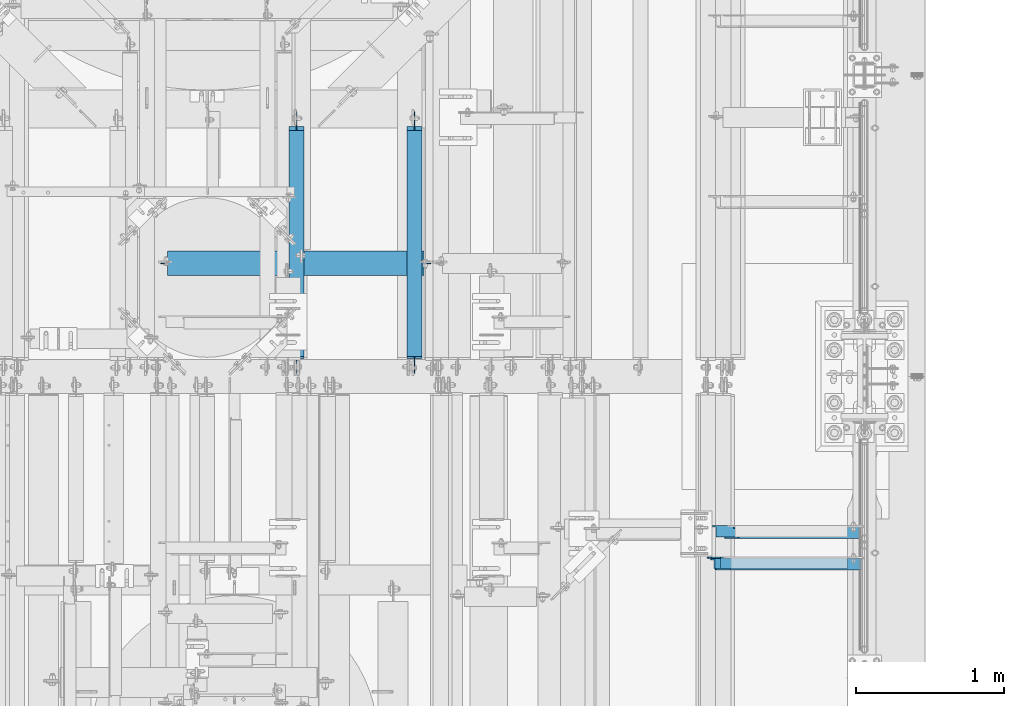
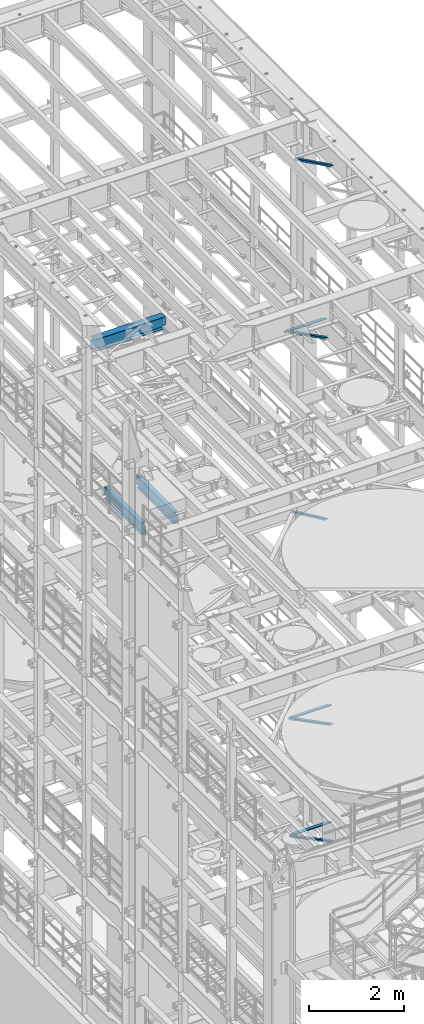
# One storey, part 1046 of 1876: 6 beams, 5 members, 11 elements without a shape of their own.
"""IFC2X3 building model written with IfcOpenShell, lengths in millimetres."""

from ifc_helpers import new_model, si_unit, frame, origin_with_axes, place, context, subcontext, project, spatial, faceted_brep, material, type_object, element, aggregate, save


model = new_model("IFC2X3")

# Units and contexts
model_context = context("Model", 3, precision=1e-05, world=origin_with_axes())
body_context = subcontext(model_context, "Body", "Model", "MODEL_VIEW")
ifc_project = project(units=[si_unit("LENGTHUNIT", "METRE", prefix="MILLI"), si_unit("AREAUNIT", "SQUARE_METRE"), si_unit("VOLUMEUNIT", "CUBIC_METRE"), si_unit("MASSUNIT", "GRAM", prefix="KILO"), si_unit("TIMEUNIT", "SECOND"), si_unit("PLANEANGLEUNIT", "RADIAN"), si_unit("SOLIDANGLEUNIT", "STERADIAN"), si_unit("THERMODYNAMICTEMPERATUREUNIT", "DEGREE_CELSIUS"), si_unit("LUMINOUSINTENSITYUNIT", "LUMEN")], contexts=[model_context])

# Site, building, storey
site_placement = place(None, origin_with_axes())
site = spatial("IfcSite", under=ifc_project, at=site_placement, CompositionType="ELEMENT")
building_placement = place(site_placement, origin_with_axes())
building = spatial("IfcBuilding", under=site, at=building_placement, Name="Undefined", CompositionType="ELEMENT")
storey_placement = place(building_placement, origin_with_axes())
storey = spatial("IfcBuildingStorey", under=building, at=storey_placement, Name="Undefined", CompositionType="ELEMENT", Elevation=0.0)

# Assembly, member
assembly_1_placement = place(storey_placement, origin_with_axes())
assembly_1 = element("IfcElementAssembly", 1, at=assembly_1_placement, inside=storey, AssemblyPlace="NOTDEFINED", PredefinedType="RIGID_FRAME")
ifc_material_1 = material(Name="STEEL/A36")
member_type = type_object("IfcMemberType", Name="L3X3X3/8", PredefinedType="NOTDEFINED")
member_1_placement = place(assembly_1_placement, frame((6549.21887719362, 6353.175, 5096.54580110531), z_axis=(0.0, -1.0, 0.0), x_axis=(0.899060338191213, 0.0, -0.437824746093117)))
member_1 = element("IfcMember", 2, at=member_1_placement, type_object=member_type, material=ifc_material_1, ObjectType="L3X3X3/8", context=body_context, shape_type="Brep", body=[
    faceted_brep([(54.7652293632691, 38.0999999999885, -38.1000000000004), (54.7652293632691, 38.0999999999885, 38.1000000000004), (1150.37468125874, 38.1000000001977, 38.1000000000004), (1150.37468125874, 38.1000000001977, -38.1000000000004), (54.7652293632686, 28.5749999999944, 38.1000000000004), (1150.37468125873, 28.5750000002035, 38.1000000000004), (54.7652293632686, 28.5749999999944, -28.5749999999998), (1150.37468125873, 28.5750000002035, -28.5749999999998), (54.7652293632682, -38.0999999999685, -28.5749999999998), (1150.37468125873, -38.0999999997593, -28.5749999999998), (54.7652293632682, -38.0999999999685, -38.1000000000004), (1150.37468125873, -38.0999999997593, -38.1000000000004)], [[[0, 1, 2, 3]], [[1, 4, 5, 2]], [[4, 6, 7, 5]], [[6, 8, 9, 7]], [[8, 10, 11, 9]], [[10, 0, 3, 11]], [[5, 7, 9, 11, 3, 2]], [[10, 8, 6, 4, 1, 0]]]),
])
aggregate(assembly_1, [member_1])

assembly_2_placement = place(storey_placement, origin_with_axes())
assembly_2 = element("IfcElementAssembly", 3, at=assembly_2_placement, inside=storey, Name="BRACE", AssemblyPlace="NOTDEFINED", PredefinedType="RIGID_FRAME")
member_2_placement = place(assembly_2_placement, frame((6673.56288386735, 6565.9, 13302.1718727092), z_axis=(0.0, -1.0, 0.0), x_axis=(0.861630637805759, 0.0, -0.507535854885584)))
member_2 = element("IfcMember", 4, at=member_2_placement, type_object=member_type, material=ifc_material_1, Name="BRACE", ObjectType="L3X3X3/8", context=body_context, shape_type="Brep", body=[
    faceted_brep([(93.8357350541173, 38.0999999999913, -38.0999999999999), (93.8357350541173, 38.0999999999913, 38.0999999999999), (1052.95263444459, 38.0999999997257, 38.0999999999999), (1052.95263444459, 38.0999999997257, -38.0999999999999), (93.8357350541228, 28.5749999999862, 38.0999999999999), (1052.95263444459, 28.5749999997206, 38.0999999999999), (93.8357350541228, 28.5749999999862, -28.5749999999998), (1052.95263444459, 28.5749999997206, -28.5749999999998), (93.8357350541537, -38.100000000044, -28.5749999999998), (1052.95263444462, -38.100000000306, -28.5749999999998), (93.8357350541537, -38.100000000044, -38.0999999999999), (1052.95263444462, -38.100000000306, -38.0999999999999)], [[[0, 1, 2, 3]], [[1, 4, 5, 2]], [[4, 6, 7, 5]], [[6, 8, 9, 7]], [[8, 10, 11, 9]], [[10, 0, 3, 11]], [[5, 7, 9, 11, 3, 2]], [[10, 8, 6, 4, 1, 0]]]),
])
aggregate(assembly_2, [member_2])

assembly_3_placement = place(storey_placement, origin_with_axes())
assembly_3 = element("IfcElementAssembly", 5, at=assembly_3_placement, inside=storey, AssemblyPlace="NOTDEFINED", PredefinedType="RIGID_FRAME")
member_3_placement = place(assembly_3_placement, frame((6649.22451200342, 6353.175, 22521.7692276093), z_axis=(0.0, -1.0, 0.0), x_axis=(0.877448093107094, 0.0, -0.479671600058544)))
member_3 = element("IfcMember", 6, at=member_3_placement, type_object=member_type, material=ifc_material_1, ObjectType="L3X3X3/8", context=body_context, shape_type="Brep", body=[
    faceted_brep([(59.7482362440578, 38.0999999998749, -38.0999999999999), (59.7482362440578, 38.0999999998749, 38.0999999999999), (1062.91900040893, 38.0999999984488, 38.0999999999999), (1062.91900040893, 38.0999999984488, -38.0999999999999), (59.7482362440696, 28.5749999998843, 38.0999999999999), (1062.91900040895, 28.5749999984582, 38.0999999999999), (59.7482362440696, 28.5749999998843, -28.5749999999998), (1062.91900040895, 28.5749999984582, -28.5749999999998), (59.7482362441442, -38.1000000000495, -28.5749999999998), (1062.91900040902, -38.1000000014719, -28.5749999999998), (59.7482362441442, -38.1000000000495, -38.0999999999999), (1062.91900040902, -38.1000000014719, -38.0999999999999)], [[[0, 1, 2, 3]], [[1, 4, 5, 2]], [[4, 6, 7, 5]], [[6, 8, 9, 7]], [[8, 10, 11, 9]], [[10, 0, 3, 11]], [[5, 7, 9, 11, 3, 2]], [[10, 8, 6, 4, 1, 0]]]),
])
aggregate(assembly_3, [member_3])

assembly_4_placement = place(storey_placement, origin_with_axes())
assembly_4 = element("IfcElementAssembly", 7, at=assembly_4_placement, inside=storey, AssemblyPlace="NOTDEFINED", PredefinedType="RIGID_FRAME")
member_4_placement = place(assembly_4_placement, frame((6548.05484608427, 6565.9, 17987.6375508032), z_axis=(0.0, -1.0, 0.0), x_axis=(0.883528850284789, 0.0, -0.46837674015096)))
member_4 = element("IfcMember", 8, at=member_4_placement, type_object=member_type, material=ifc_material_1, ObjectType="L3X3X3/8", context=body_context, shape_type="Brep", body=[
    faceted_brep([(128.795891913077, 38.1000000000095, -38.0999999999999), (128.795891913077, 38.1000000000095, 38.0999999999999), (1170.59703232476, 38.0999999999913, 38.0999999999999), (1170.59703232476, 38.0999999999913, -38.0999999999999), (128.795891913076, 28.575000000008, 38.0999999999999), (1170.59703232476, 28.5749999999898, 38.0999999999999), (128.795891913076, 28.575000000008, -28.5749999999998), (1170.59703232476, 28.5749999999898, -28.5749999999998), (128.79589191308, -38.1000000000167, -28.5749999999998), (1170.59703232476, -38.1000000000313, -28.5749999999998), (128.79589191308, -38.1000000000167, -38.0999999999999), (1170.59703232476, -38.1000000000313, -38.0999999999999)], [[[0, 1, 2, 3]], [[1, 4, 5, 2]], [[4, 6, 7, 5]], [[6, 8, 9, 7]], [[8, 10, 11, 9]], [[10, 0, 3, 11]], [[5, 7, 9, 11, 3, 2]], [[10, 8, 6, 4, 1, 0]]]),
])
aggregate(assembly_4, [member_4])

assembly_5_placement = place(storey_placement, origin_with_axes())
assembly_5 = element("IfcElementAssembly", 9, at=assembly_5_placement, inside=storey, AssemblyPlace="NOTDEFINED", PredefinedType="RIGID_FRAME")
member_5_placement = place(assembly_5_placement, frame((6536.16116201617, 6353.175, 8132.02232402439), z_axis=(0.0, -1.0, 0.0), x_axis=(0.894427191199916, 0.0, -0.447213595099958)))
member_5 = element("IfcMember", 10, at=member_5_placement, type_object=member_type, material=ifc_material_1, ObjectType="L3X3X3/8", context=body_context, shape_type="Brep", body=[
    faceted_brep([(78.0946740306676, 38.1000000000076, -38.0999999999999), (78.0946740306676, 38.1000000000076, 38.0999999999999), (1170.5326724749, 38.0999999997912, 38.0999999999999), (1170.5326724749, 38.0999999997912, -38.0999999999999), (78.0946740306676, 28.5750000000025, 38.0999999999999), (1170.5326724749, 28.5749999997861, 38.0999999999999), (78.0946740306676, 28.5750000000025, -28.5749999999998), (1170.5326724749, 28.5749999997861, -28.5749999999998), (78.0946740306667, -38.1000000000367, -28.5749999999998), (1170.5326724749, -38.1000000002532, -28.5749999999998), (78.0946740306667, -38.1000000000367, -38.0999999999999), (1170.5326724749, -38.1000000002532, -38.0999999999999)], [[[0, 1, 2, 3]], [[1, 4, 5, 2]], [[4, 6, 7, 5]], [[6, 8, 9, 7]], [[8, 10, 11, 9]], [[10, 0, 3, 11]], [[5, 7, 9, 11, 3, 2]], [[10, 8, 6, 4, 1, 0]]]),
])
aggregate(assembly_5, [member_5])

# Assembly, beam
assembly_6_placement = place(storey_placement, origin_with_axes())
assembly_6 = element("IfcElementAssembly", 11, at=assembly_6_placement, inside=storey, Name="BEAM", AssemblyPlace="NOTDEFINED", PredefinedType="RIGID_FRAME")
ifc_material_2 = material(Name="STEEL/A992")
beam_type_1 = type_object("IfcBeamType", Name="W12X26", PredefinedType="NOTDEFINED")
beam_1_placement = place(assembly_6_placement, frame((2857.5, 8382.0, 17827.625), z_axis=(0.0, 0.0, 1.0), x_axis=(1.0, 0.0, 0.0)))
beam_1 = element("IfcBeam", 12, at=beam_1_placement, type_object=beam_type_1, material=ifc_material_2, Name="BEAM", ObjectType="W12X26", context=body_context, shape_type="Brep", body=[
    faceted_brep([(1746.25, -3.17499999999927, -146.049999999999), (1746.25, -82.5499999999993, -146.049999999999), (1746.25, -82.5499999999993, -155.575000000001), (1746.25, 82.5499999999993, -155.575000000001), (1746.25, 82.5499999999993, -146.049999999999), (1746.25, 3.17499999999927, -146.049999999999), (1746.25, 3.17499999999927, -136.524999809262), (1746.25, -3.17499999999927, -136.524999809262), (1747.21672992259, 3.17499999999927, -131.664920291216), (1747.21672992259, -3.17499999999927, -131.664920291216), (1749.96974382307, 3.17499999999927, -127.544743823062), (1749.96974382307, -3.17499999999927, -127.544743823062), (1754.08992029122, 3.17499999999927, -124.791729922585), (1754.08992029122, -3.17499999999927, -124.791729922585), (1758.94999980927, 3.17499999999927, -123.824999999997), (1758.94999980927, -3.17499999999927, -123.824999999997), (1838.325, -3.17499999999927, -123.824999999997), (1838.325, 3.17499999999927, -123.824999999997), (63.5000000000009, 3.17499999999927, 146.049999999999), (63.5000000000009, 82.5499999999993, 146.049999999999), (1790.7, 82.5499999999993, 146.049999999999), (1790.7, 3.17499999999927, 146.049999999999), (107.950000000001, -3.17499999999927, -136.524999809262), (107.950000000001, 3.17499999999927, -136.524999809262), (107.950000000001, 3.17499999999927, -146.049999999999), (107.950000000001, 82.5499999999993, -146.049999999999), (107.950000000001, 82.5499999999993, -155.575000000001), (107.950000000001, -82.5499999999993, -155.575000000001), (107.950000000001, -82.5499999999993, -146.049999999999), (107.950000000001, -3.17499999999927, -146.049999999999), (106.983270077413, -3.17499999999927, -131.664920291216), (106.983270077413, 3.17499999999927, -131.664920291216), (104.230256176935, -3.17499999999927, -127.544743823062), (104.230256176935, 3.17499999999927, -127.544743823062), (100.110079708781, -3.17499999999927, -124.791729922585), (100.110079708781, 3.17499999999927, -124.791729922585), (95.2500001907356, -3.17499999999927, -123.824999999997), (95.2500001907356, 3.17499999999927, -123.824999999997), (15.875, -3.17499999999927, -123.824999999997), (15.875, 3.17499999999927, -123.824999999997), (15.875, -3.17500000000018, 117.474999999999), (15.875, 3.17500000000018, 117.474999999999), (50.8000001907358, -3.17499999999927, 117.475000000002), (50.8000001907358, 3.17499999999927, 117.475000000002), (55.6600797087813, -3.17499999999927, 118.44172992259), (55.6600797087813, 3.17499999999927, 118.44172992259), (59.7802561769349, -3.17499999999927, 121.194743823067), (59.7802561769349, 3.17499999999927, 121.194743823067), (62.5332700774129, -3.17499999999927, 125.314920291221), (62.5332700774129, 3.17499999999927, 125.314920291221), (63.5000000000009, -3.17499999999927, 130.174999809267), (63.5000000000009, 3.17499999999927, 130.174999809267), (63.5000000000009, -82.5499999999993, 155.575000000001), (63.5000000000009, 82.5499999999993, 155.575000000001), (63.5000000000009, -3.17499999999927, 146.049999999999), (63.5000000000009, -82.5499999999993, 146.049999999999), (1790.7, -3.17499999999927, 146.049999999999), (1790.7, -82.5499999999993, 146.049999999999), (1790.7, -82.5499999999993, 155.575000000001), (1790.7, 82.5499999999993, 155.575000000001), (1790.7, -3.17499999999927, 130.174999809267), (1790.7, 3.17499999999927, 130.174999809267), (1791.66672992259, -3.17499999999927, 125.314920291221), (1791.66672992259, 3.17499999999927, 125.314920291221), (1794.41974382307, -3.17499999999927, 121.194743823067), (1794.41974382307, 3.17499999999927, 121.194743823067), (1798.53992029122, -3.17499999999927, 118.44172992259), (1798.53992029122, 3.17499999999927, 118.44172992259), (1803.39999980927, -3.17499999999927, 117.475000000002), (1803.39999980927, 3.17499999999927, 117.475000000002), (1838.325, -3.17499999999927, 117.475000000002), (1838.325, 3.17499999999927, 117.475000000002)], [[[0, 1, 2, 3, 4, 5, 6, 7]], [[7, 6, 8, 9]], [[9, 8, 10, 11]], [[11, 10, 12, 13]], [[13, 12, 14, 15]], [[16, 15, 14, 17]], [[18, 19, 20, 21]], [[22, 23, 24, 25, 26, 27, 28, 29]], [[30, 31, 23, 22]], [[32, 33, 31, 30]], [[34, 35, 33, 32]], [[36, 37, 35, 34]], [[38, 39, 37, 36]], [[40, 41, 39, 38]], [[42, 43, 41, 40]], [[44, 45, 43, 42]], [[46, 47, 45, 44]], [[48, 49, 47, 46]], [[50, 51, 49, 48]], [[52, 53, 19, 18, 51, 50, 54, 55]], [[55, 54, 56, 57]], [[52, 55, 57, 58]], [[53, 52, 58, 59]], [[19, 53, 59, 20]], [[58, 57, 56, 60, 61, 21, 20, 59]], [[62, 63, 61, 60]], [[64, 65, 63, 62]], [[66, 67, 65, 64]], [[68, 69, 67, 66]], [[70, 71, 69, 68]], [[71, 70, 16, 17]], [[12, 10, 8, 6, 5, 24, 23, 31, 33, 35, 37, 39, 41, 43, 45, 47, 49, 51, 18, 21, 61, 63, 65, 67, 69, 71, 17, 14]], [[25, 24, 5, 4]], [[26, 25, 4, 3]], [[27, 26, 3, 2]], [[28, 27, 2, 1]], [[29, 28, 1, 0]], [[70, 68, 66, 64, 62, 60, 56, 54, 50, 48, 46, 44, 42, 40, 38, 36, 34, 32, 30, 22, 29, 0, 7, 9, 11, 13, 15, 16]]]),
])
aggregate(assembly_6, [beam_1])

assembly_7_placement = place(storey_placement, origin_with_axes())
assembly_7 = element("IfcElementAssembly", 13, at=assembly_7_placement, inside=storey, Name="ANGLE", AssemblyPlace="NOTDEFINED", PredefinedType="RIGID_FRAME")
beam_type_2 = type_object("IfcBeamType", Name="L3X3X3/8", PredefinedType="NOTDEFINED")
beam_2_placement = place(assembly_7_placement, frame((6565.90000005887, 6575.425, 17945.1), z_axis=(0.0, -1.0, 0.0), x_axis=(1.0, 0.0, 0.0)))
beam_2 = element("IfcBeam", 14, at=beam_2_placement, type_object=beam_type_2, material=ifc_material_1, Name="ANGLE", ObjectType="L3X3X3/8", context=body_context, shape_type="Brep", body=[
    faceted_brep([(52.3875000813496, 38.0999999999985, 38.0999999999858), (52.3875000813123, 28.5750001907327, 38.0999999999858), (938.213001286278, 28.5750000000007, 38.0999999999999), (938.213001286278, 38.0999999999985, 38.0999999999999), (52.3875051486311, 28.5750000000007, -28.5750000000144), (938.213000419482, 28.5750000000007, -28.5749999999998), (1015.20625603472, 12.6999992370475, -28.5749999999998), (1015.20625591089, 12.6999992370475, -38.0999999999999), (938.213000295654, 12.6999992370475, -38.0999999999999), (938.213000419482, 12.6999992370475, -28.5749999999998), (938.213000295654, 38.0999999999985, -38.0999999999999), (52.3875058725371, 38.0999999999985, -38.1000000000149), (52.3875058725339, 28.5750001907327, -38.1000000000149), (15.8749999382144, 28.5750001907327, -38.0999999999999), (15.8749936676099, 28.5749999999989, -28.5750000000007), (3.17500012894925, 15.8750003814675, -38.0999999999999), (3.17500032897624, 15.8750003814675, -28.5749999999998), (3.17499999075153, -38.0999999999985, -28.5749999999998), (3.17499999075153, -38.0999999999985, -38.0999999999999), (1046.95625011747, -38.0999999999985, -28.5749999999998), (1046.95625603472, -19.0500007629525, -28.5749999999998), (1046.95625591089, -19.0500007629525, -38.0999999999999), (1046.95625011747, -38.0999999999985, -38.0999999999999)], [[[0, 1, 2, 3]], [[1, 4, 5, 2]], [[6, 7, 8, 9]], [[2, 5, 9, 8, 10, 3]], [[11, 0, 3, 10]], [[1, 0, 11, 12, 4]], [[4, 12, 13, 14]], [[14, 13, 15, 16]], [[17, 16, 15, 18]], [[6, 9, 5, 4, 14, 16, 17, 19, 20]], [[7, 6, 20, 21]], [[18, 15, 13, 12, 11, 10, 8, 7, 21, 22]], [[17, 18, 22, 19]], [[21, 20, 19, 22]]]),
])
aggregate(assembly_7, [beam_2])

assembly_8_placement = place(storey_placement, origin_with_axes())
assembly_8 = element("IfcElementAssembly", 15, at=assembly_8_placement, inside=storey, Name="ANGLE", AssemblyPlace="NOTDEFINED", PredefinedType="RIGID_FRAME")
beam_3_placement = place(assembly_8_placement, frame((6553.19999999857, 6362.7, 8115.3), z_axis=(0.0, -1.0, 0.0), x_axis=(1.0, 0.0, 0.0)))
beam_3 = element("IfcBeam", 16, at=beam_3_placement, type_object=beam_type_2, material=ifc_material_1, Name="ANGLE", ObjectType="L3X3X3/8", context=body_context, shape_type="Brep", body=[
    faceted_brep([(950.913000303442, 28.5749999999998, -28.5749999999998), (950.913001170238, 28.5749999999998, 38.0999999999999), (52.3870335430847, 28.5750001907327, 38.0999999999858), (52.3869956588824, 28.5749999999955, -28.5750000000007), (950.913001170238, 38.1000000000004, 38.0999999999999), (52.387033543122, 38.0999999999985, 38.0999999999858), (15.8749936676099, 28.5749999999989, -28.5750000000007), (15.8749999382144, 28.5750001907327, -38.0999999999999), (3.17500012894925, 15.8750003814675, -38.0999999999999), (3.17500032897624, 15.8750003814675, -28.5749999999998), (52.3870393343063, 28.5750001907327, -38.1000000000149), (52.3869953826566, 38.0999999999954, -38.0999999999985), (950.913000179614, 38.1000000000004, -38.0999999999999), (950.913000303442, 12.6999992370611, -28.5749999999998), (950.913000179614, 12.6999992370611, -38.0999999999999), (1027.90624828928, 12.6999992370611, -28.5749999999998), (1027.90624816545, 12.6999992370611, -38.0999999999999), (1059.65624828928, -19.0500007629389, -28.5749999999998), (1059.65624816545, -19.0500007629389, -38.0999999999999), (1059.65625000143, -38.1000000000004, -28.5749999999998), (1059.65625000143, -38.1000000000004, -38.0999999999999), (3.17499999075153, -38.0999999999985, -28.5749999999998), (3.17499999075153, -38.0999999999985, -38.0999999999999), (3.17500012894925, 3.17500152587672, -38.0999999999999), (3.17500032897624, 3.17500152587672, -28.5749999999998)], [[[0, 1, 2, 3]], [[1, 4, 5, 2]], [[6, 7, 8, 9]], [[3, 10, 7, 6]], [[2, 5, 11, 10, 3]], [[4, 12, 11, 5]], [[1, 0, 13, 14, 12, 4]], [[15, 16, 14, 13]], [[16, 15, 17, 18]], [[18, 17, 19, 20]], [[20, 19, 21, 22]], [[8, 7, 10, 11, 12, 14, 16, 18, 20, 22, 23]], [[9, 8, 23, 24]], [[19, 17, 15, 13, 0, 3, 6, 9, 24, 21]], [[23, 22, 21, 24]]]),
])
aggregate(assembly_8, [beam_3])

assembly_9_placement = place(storey_placement, origin_with_axes())
assembly_9 = element("IfcElementAssembly", 17, at=assembly_9_placement, inside=storey, Name="ANGLE", AssemblyPlace="NOTDEFINED", PredefinedType="RIGID_FRAME")
beam_4_placement = place(assembly_9_placement, frame((6489.7, 6362.7, 5092.7), z_axis=(0.0, -1.0, 0.0), x_axis=(1.0, 0.0, 0.0)))
beam_4 = element("IfcBeam", 18, at=beam_4_placement, type_object=beam_type_2, material=ifc_material_1, Name="ANGLE", ObjectType="L3X3X3/8", context=body_context, shape_type="Brep", body=[
    faceted_brep([(1014.41300030201, 28.5749999999998, -28.5749999999998), (1014.41300116881, 28.5749999999998, 38.1000000000004), (160.337055571042, 28.5749999999998, 38.1000000000004), (160.337055570792, 28.5749999999998, -28.5749999999998), (1014.41300116881, 38.1000000000004, 38.1000000000004), (160.337388892724, 38.1000000000004, 38.1000000000004), (98.4249977111795, 26.9870083759042, -28.5749999999998), (98.4249977111795, 26.9870093950822, -38.1000000000004), (79.3749984741189, 7.93701015802071, -38.1000000000004), (79.3749984741189, 7.93700913884368, -28.5749999999998), (160.336999999974, 26.9870083759042, -28.5749999999998), (160.336999999974, 26.9870093950822, -38.1000000000004), (160.337388892438, 38.1000000000004, -38.1000000000004), (1014.41300017818, 38.1000000000004, -38.1000000000004), (1014.41300030201, 12.6999992370611, -28.5749999999998), (1014.41300017818, 12.6999992370611, -38.1000000000004), (1091.40624828785, 12.6999992370611, -28.5749999999998), (1091.40624816402, 12.6999992370611, -38.1000000000004), (1123.15624828785, -19.0500007629389, -28.5749999999998), (1123.15624816402, -19.0500007629389, -38.1000000000004), (1123.15625, -38.1000000000004, -28.5749999999998), (1123.15625, -38.1000000000004, -38.1000000000004), (79.375, -38.1000000000004, -28.5749999999998), (79.375, -38.1000000000004, -38.1000000000004), (79.3749984741189, 1.58700977655099, -38.1000000000004), (79.3749984741189, 1.58700875737395, -28.5749999999998)], [[[0, 1, 2, 3]], [[1, 4, 5, 2]], [[6, 7, 8, 9]], [[10, 11, 7, 6]], [[2, 5, 12, 11, 10, 3]], [[4, 13, 12, 5]], [[1, 0, 14, 15, 13, 4]], [[16, 17, 15, 14]], [[17, 16, 18, 19]], [[19, 18, 20, 21]], [[21, 20, 22, 23]], [[8, 7, 11, 12, 13, 15, 17, 19, 21, 23, 24]], [[9, 8, 24, 25]], [[20, 18, 16, 14, 0, 3, 10, 6, 9, 25, 22]], [[24, 23, 22, 25]]]),
])
aggregate(assembly_9, [beam_4])

assembly_10_placement = place(storey_placement, origin_with_axes())
assembly_10 = element("IfcElementAssembly", 19, at=assembly_10_placement, inside=storey, Name="BEAM", AssemblyPlace="NOTDEFINED", PredefinedType="RIGID_FRAME")
beam_type_3 = type_object("IfcBeamType", Name="W12X16", PredefinedType="NOTDEFINED")
beam_5_placement = place(assembly_10_placement, frame((4584.70000000002, 7620.0, 13157.2), z_axis=(0.0, 0.0, 1.0), x_axis=(0.0, 1.0, 0.0)))
beam_5 = element("IfcBeam", 20, at=beam_5_placement, type_object=beam_type_3, material=ifc_material_2, Name="BEAM", ObjectType="W12X16", context=body_context, shape_type="Brep", body=[
    faceted_brep([(1683.54375, -3.17500000000018, -146.049999999999), (1683.54375, -50.8000000000002, -146.049999999999), (1683.54375, -50.8000000000002, -152.4), (1683.54375, 50.8000000000002, -152.4), (1683.54375, 50.8000000000002, -146.049999999999), (1683.54375, 3.17500000000018, -146.049999999999), (1683.54375, 3.17500000000018, -139.699999809267), (1683.54375, -3.17500000000018, -139.699999809267), (1684.51047992259, 3.17500000000018, -134.839920291221), (1684.51047992259, -3.17500000000018, -134.839920291221), (1687.26349382307, 3.17500000000018, -130.719743823067), (1687.26349382307, -3.17500000000018, -130.719743823067), (1691.38367029122, 3.17500000000018, -127.966729922589), (1691.38367029122, -3.17500000000018, -127.966729922589), (1696.24374980926, 3.17500000000018, -127.000000000002), (1696.24374980926, -3.17500000000018, -127.000000000002), (1785.14375, -3.17500000000018, -127.000000000002), (1785.14375, 3.17500000000018, -127.000000000002), (134.14375, 3.17500000000018, 146.049999999999), (134.14375, 50.8000000000002, 146.049999999999), (1658.14375, 50.8000000000002, 146.049999999999), (1658.14375, 3.17500000000018, 146.049999999999), (121.44375, -3.17500000000018, -139.699999809265), (121.44375, 3.17500000000018, -139.699999809265), (121.44375, 3.17500000000018, -146.049999999999), (121.44375, 50.8000000000002, -146.049999999999), (121.44375, 50.8000000000002, -152.4), (121.44375, -50.8000000000002, -152.4), (121.44375, -50.8000000000002, -146.049999999999), (121.44375, -3.17500000000018, -146.049999999999), (120.477020077413, -3.17500000000018, -134.839920291219), (120.477020077413, 3.17500000000018, -134.839920291219), (117.724006176934, -3.17500000000018, -130.719743823065), (117.724006176934, 3.17500000000018, -130.719743823065), (113.603829708781, -3.17500000000018, -127.966729922588), (113.603829708781, 3.17500000000018, -127.966729922588), (108.743750190735, -3.17500000000018, -127.0), (108.743750190735, 3.17500000000018, -127.0), (19.84375, -3.17499999999995, -126.999999999996), (19.84375, 3.17499999999995, -126.999999999996), (19.84375, -3.17500000000018, 114.299999999999), (19.84375, 3.17500000000018, 114.299999999999), (121.443750190735, -3.17500000000018, 114.299999999999), (121.443750190735, 3.17500000000018, 114.299999999999), (126.303829708781, -3.17500000000018, 115.266729922587), (126.303829708781, 3.17500000000018, 115.266729922587), (130.424006176934, -3.17500000000018, 118.019743823064), (130.424006176934, 3.17500000000018, 118.019743823064), (133.177020077413, -3.17500000000018, 122.139920291218), (133.177020077413, 3.17500000000018, 122.139920291218), (134.14375, -3.17500000000018, 126.999999809264), (134.14375, 3.17500000000018, 126.999999809264), (134.14375, -50.8000000000002, 152.4), (134.14375, 50.8000000000002, 152.4), (134.14375, -3.17500000000018, 146.049999999999), (134.14375, -50.8000000000002, 146.049999999999), (1658.14375, -3.17500000000018, 146.049999999999), (1658.14375, -50.8000000000002, 146.049999999999), (1658.14375, -50.8000000000002, 152.4), (1658.14375, 50.8000000000002, 152.4), (1658.14375, -3.17500000000018, 120.649999809264), (1658.14375, 3.17500000000018, 120.649999809264), (1659.11047992259, -3.17500000000018, 115.789920291218), (1659.11047992259, 3.17500000000018, 115.789920291218), (1661.86349382306, -3.17500000000018, 111.669743823064), (1661.86349382306, 3.17500000000018, 111.669743823064), (1665.98367029122, -3.17500000000018, 108.916729922586), (1665.98367029122, 3.17500000000018, 108.916729922586), (1670.84374980926, -3.17500000000018, 107.949999999999), (1670.84374980926, 3.17500000000018, 107.949999999999), (1785.14375, -3.17500000000018, 107.949999999999), (1785.14375, 3.17500000000018, 107.949999999999)], [[[0, 1, 2, 3, 4, 5, 6, 7]], [[7, 6, 8, 9]], [[9, 8, 10, 11]], [[11, 10, 12, 13]], [[13, 12, 14, 15]], [[16, 15, 14, 17]], [[18, 19, 20, 21]], [[22, 23, 24, 25, 26, 27, 28, 29]], [[30, 31, 23, 22]], [[32, 33, 31, 30]], [[34, 35, 33, 32]], [[36, 37, 35, 34]], [[38, 39, 37, 36]], [[40, 41, 39, 38]], [[42, 43, 41, 40]], [[44, 45, 43, 42]], [[46, 47, 45, 44]], [[48, 49, 47, 46]], [[50, 51, 49, 48]], [[52, 53, 19, 18, 51, 50, 54, 55]], [[55, 54, 56, 57]], [[52, 55, 57, 58]], [[53, 52, 58, 59]], [[19, 53, 59, 20]], [[58, 57, 56, 60, 61, 21, 20, 59]], [[62, 63, 61, 60]], [[64, 65, 63, 62]], [[66, 67, 65, 64]], [[68, 69, 67, 66]], [[70, 71, 69, 68]], [[71, 70, 16, 17]], [[12, 10, 8, 6, 5, 24, 23, 31, 33, 35, 37, 39, 41, 43, 45, 47, 49, 51, 18, 21, 61, 63, 65, 67, 69, 71, 17, 14]], [[25, 24, 5, 4]], [[26, 25, 4, 3]], [[27, 26, 3, 2]], [[28, 27, 2, 1]], [[29, 28, 1, 0]], [[70, 68, 66, 64, 62, 60, 56, 54, 50, 48, 46, 44, 42, 40, 38, 36, 34, 32, 30, 22, 29, 0, 7, 9, 11, 13, 15, 16]]]),
])
aggregate(assembly_10, [beam_5])

assembly_11_placement = place(storey_placement, origin_with_axes())
assembly_11 = element("IfcElementAssembly", 21, at=assembly_11_placement, inside=storey, Name="BEAM", AssemblyPlace="NOTDEFINED", PredefinedType="RIGID_FRAME")
beam_6_placement = place(assembly_11_placement, frame((3790.95, 7620.0, 13157.2), z_axis=(0.0, 0.0, 1.0), x_axis=(0.0, 1.0, 0.0)))
beam_6 = element("IfcBeam", 22, at=beam_6_placement, type_object=beam_type_3, material=ifc_material_2, Name="BEAM", ObjectType="W12X16", context=body_context, shape_type="Brep", body=[
    faceted_brep([(1683.54375, -3.17500000000018, -146.049999999999), (1683.54375, -50.8000000000002, -146.049999999999), (1683.54375, -50.8000000000002, -152.4), (1683.54375, 50.8000000000002, -152.4), (1683.54375, 50.8000000000002, -146.049999999999), (1683.54375, 3.17500000000018, -146.049999999999), (1683.54375, 3.17500000000018, -139.699999809267), (1683.54375, -3.17500000000018, -139.699999809267), (1684.51047992259, 3.17500000000018, -134.839920291221), (1684.51047992259, -3.17500000000018, -134.839920291221), (1687.26349382307, 3.17500000000018, -130.719743823067), (1687.26349382307, -3.17500000000018, -130.719743823067), (1691.38367029122, 3.17500000000018, -127.966729922589), (1691.38367029122, -3.17500000000018, -127.966729922589), (1696.24374980926, 3.17500000000018, -127.000000000002), (1696.24374980926, -3.17500000000018, -127.000000000002), (1785.14375, -3.17500000000018, -127.000000000002), (1785.14375, 3.17500000000018, -127.000000000002), (134.14375, 3.17500000000018, 146.049999999999), (134.14375, 50.8000000000002, 146.049999999999), (1658.14375, 50.8000000000002, 146.049999999999), (1658.14375, 3.17500000000018, 146.049999999999), (121.44375, -3.17500000000018, -139.699999809265), (121.44375, 3.17500000000018, -139.699999809265), (121.44375, 3.17500000000018, -146.049999999999), (121.44375, 50.8000000000002, -146.049999999999), (121.44375, 50.8000000000002, -152.4), (121.44375, -50.8000000000002, -152.4), (121.44375, -50.8000000000002, -146.049999999999), (121.44375, -3.17500000000018, -146.049999999999), (120.477020077413, -3.17500000000018, -134.839920291219), (120.477020077413, 3.17500000000018, -134.839920291219), (117.724006176934, -3.17500000000018, -130.719743823065), (117.724006176934, 3.17500000000018, -130.719743823065), (113.603829708781, -3.17500000000018, -127.966729922588), (113.603829708781, 3.17500000000018, -127.966729922588), (108.743750190735, -3.17500000000018, -127.0), (108.743750190735, 3.17500000000018, -127.0), (19.84375, -3.17499999999995, -126.999999999996), (19.84375, 3.17499999999995, -126.999999999996), (19.84375, -3.17500000000018, 114.299999999999), (19.84375, 3.17500000000018, 114.299999999999), (121.443750190735, -3.17500000000018, 114.299999999999), (121.443750190735, 3.17500000000018, 114.299999999999), (126.303829708781, -3.17500000000018, 115.266729922587), (126.303829708781, 3.17500000000018, 115.266729922587), (130.424006176934, -3.17500000000018, 118.019743823064), (130.424006176934, 3.17500000000018, 118.019743823064), (133.177020077413, -3.17500000000018, 122.139920291218), (133.177020077413, 3.17500000000018, 122.139920291218), (134.14375, -3.17500000000018, 126.999999809264), (134.14375, 3.17500000000018, 126.999999809264), (134.14375, -50.8000000000002, 152.4), (134.14375, 50.8000000000002, 152.4), (134.14375, -3.17500000000018, 146.049999999999), (134.14375, -50.8000000000002, 146.049999999999), (1658.14375, -3.17500000000018, 146.049999999999), (1658.14375, -50.8000000000002, 146.049999999999), (1658.14375, -50.8000000000002, 152.4), (1658.14375, 50.8000000000002, 152.4), (1658.14375, -3.17500000000018, 120.649999809264), (1658.14375, 3.17500000000018, 120.649999809264), (1659.11047992259, -3.17500000000018, 115.789920291218), (1659.11047992259, 3.17500000000018, 115.789920291218), (1661.86349382306, -3.17500000000018, 111.669743823064), (1661.86349382306, 3.17500000000018, 111.669743823064), (1665.98367029122, -3.17500000000018, 108.916729922586), (1665.98367029122, 3.17500000000018, 108.916729922586), (1670.84374980926, -3.17500000000018, 107.949999999999), (1670.84374980926, 3.17500000000018, 107.949999999999), (1785.14375, -3.17500000000018, 107.949999999999), (1785.14375, 3.17500000000018, 107.949999999999)], [[[0, 1, 2, 3, 4, 5, 6, 7]], [[7, 6, 8, 9]], [[9, 8, 10, 11]], [[11, 10, 12, 13]], [[13, 12, 14, 15]], [[16, 15, 14, 17]], [[18, 19, 20, 21]], [[22, 23, 24, 25, 26, 27, 28, 29]], [[30, 31, 23, 22]], [[32, 33, 31, 30]], [[34, 35, 33, 32]], [[36, 37, 35, 34]], [[38, 39, 37, 36]], [[40, 41, 39, 38]], [[42, 43, 41, 40]], [[44, 45, 43, 42]], [[46, 47, 45, 44]], [[48, 49, 47, 46]], [[50, 51, 49, 48]], [[52, 53, 19, 18, 51, 50, 54, 55]], [[55, 54, 56, 57]], [[52, 55, 57, 58]], [[53, 52, 58, 59]], [[19, 53, 59, 20]], [[58, 57, 56, 60, 61, 21, 20, 59]], [[62, 63, 61, 60]], [[64, 65, 63, 62]], [[66, 67, 65, 64]], [[68, 69, 67, 66]], [[70, 71, 69, 68]], [[71, 70, 16, 17]], [[12, 10, 8, 6, 5, 24, 23, 31, 33, 35, 37, 39, 41, 43, 45, 47, 49, 51, 18, 21, 61, 63, 65, 67, 69, 71, 17, 14]], [[25, 24, 5, 4]], [[26, 25, 4, 3]], [[27, 26, 3, 2]], [[28, 27, 2, 1]], [[29, 28, 1, 0]], [[70, 68, 66, 64, 62, 60, 56, 54, 50, 48, 46, 44, 42, 40, 38, 36, 34, 32, 30, 22, 29, 0, 7, 9, 11, 13, 15, 16]]]),
])
aggregate(assembly_11, [beam_6])

save(model, "model.ifc")
